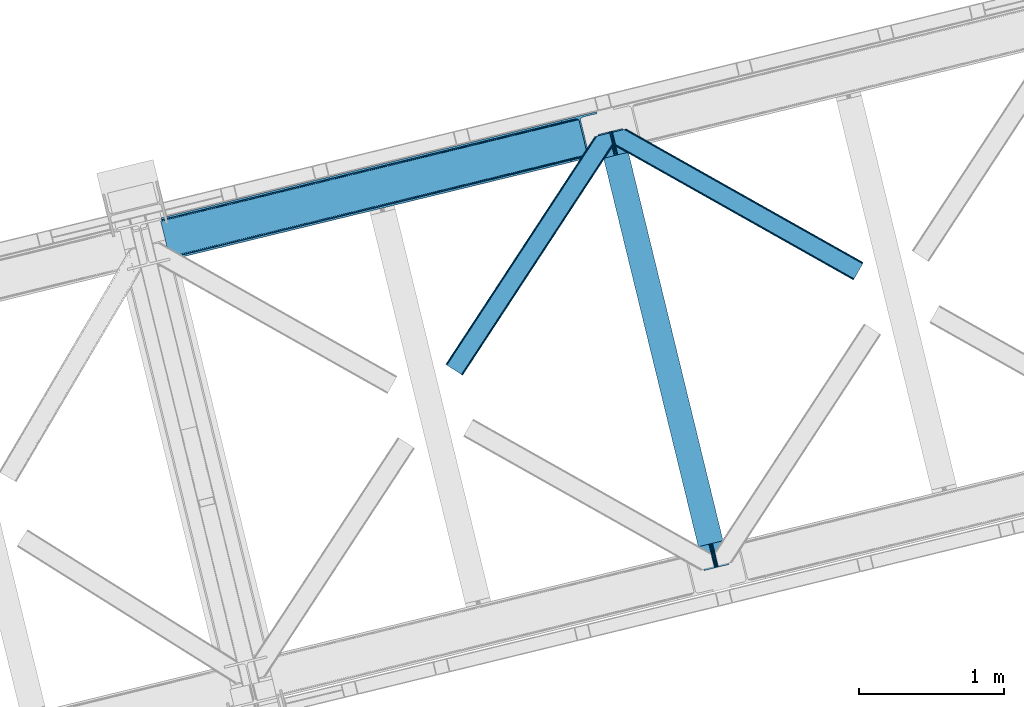
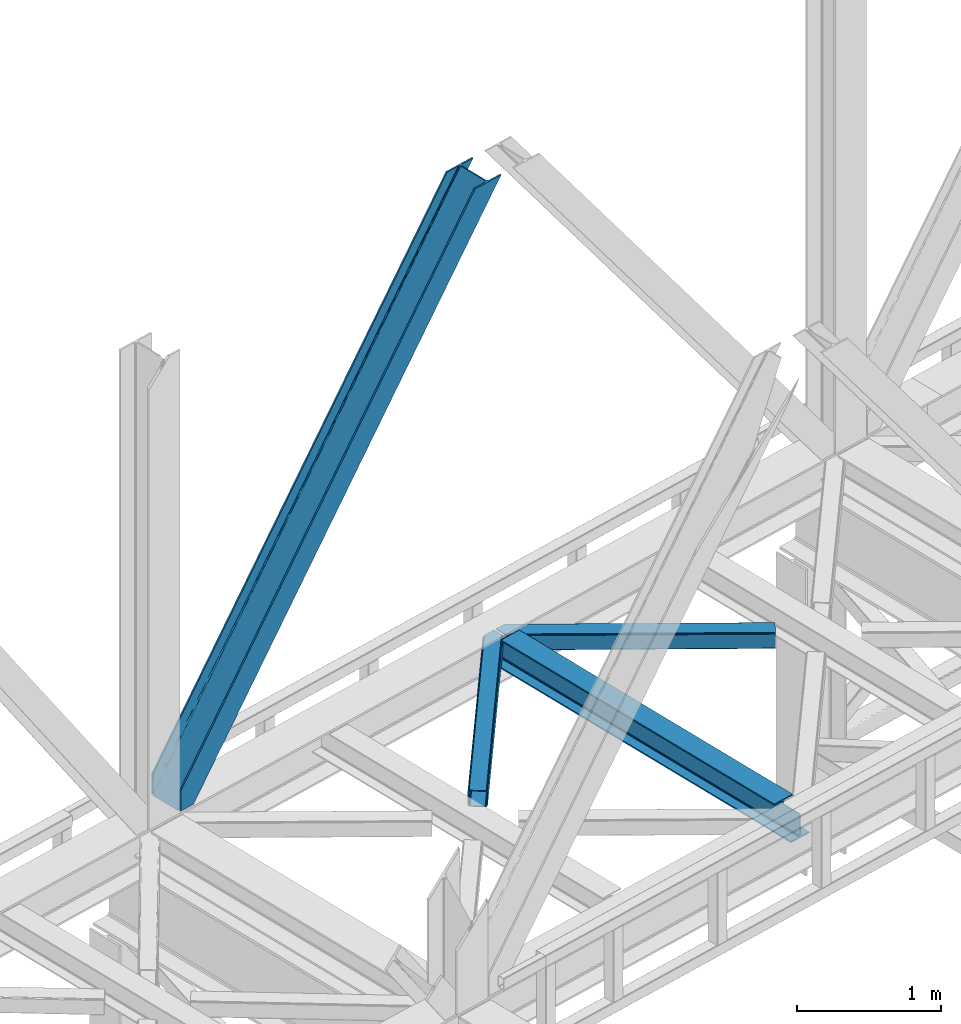
# One storey, part 40 of 93: 3 members, 1 beam.
"""IFC4 building model written with IfcOpenShell, lengths in millimetres."""

from ifc_helpers import new_model, entity, si_unit, converted_unit, derived_unit, direction, frame, origin, place, context, subcontext, project, spatial, triangles, polygons, material, type_object, element, save


model = new_model("IFC4")

# Units and contexts
model_context = context("Model", 3, precision=0.01, world=origin(), true_north=direction((6.12303176911189e-17, 1.0)))
plan_context = context("Plan", 3, precision=0.01, world=origin(), true_north=direction((6.12303176911189e-17, 1.0)))
body_context = subcontext(model_context, "Body", "Model", "MODEL_VIEW")
ifc_project = project(units=[si_unit("LENGTHUNIT", "METRE", prefix="MILLI"), si_unit("AREAUNIT", "SQUARE_METRE"), si_unit("VOLUMEUNIT", "CUBIC_METRE"), converted_unit("PLANEANGLEUNIT", "DEGREE", entity("IfcRatioMeasure", 0.0174532925199433), si_unit("PLANEANGLEUNIT", "RADIAN"), dimensions=[0, 0, 0, 0, 0, 0, 0]), si_unit("MASSUNIT", "GRAM", prefix="KILO"), derived_unit("MASSDENSITYUNIT", [(si_unit("MASSUNIT", "GRAM", prefix="KILO"), 1), (si_unit("LENGTHUNIT", "METRE"), -3)]), derived_unit("MOMENTOFINERTIAUNIT", [(si_unit("LENGTHUNIT", "METRE"), 4)]), si_unit("TIMEUNIT", "SECOND"), si_unit("FREQUENCYUNIT", "HERTZ"), si_unit("THERMODYNAMICTEMPERATUREUNIT", "DEGREE_CELSIUS"), derived_unit("THERMALTRANSMITTANCEUNIT", [(si_unit("MASSUNIT", "GRAM", prefix="KILO"), 1), (si_unit("THERMODYNAMICTEMPERATUREUNIT", "KELVIN"), -1), (si_unit("TIMEUNIT", "SECOND"), -3)]), derived_unit("VOLUMETRICFLOWRATEUNIT", [(si_unit("LENGTHUNIT", "METRE"), 3), (si_unit("TIMEUNIT", "SECOND"), -1)]), derived_unit("MASSFLOWRATEUNIT", [(si_unit("MASSUNIT", "GRAM", prefix="KILO"), 1), (si_unit("TIMEUNIT", "SECOND"), -1)]), derived_unit("ROTATIONALFREQUENCYUNIT", [(si_unit("TIMEUNIT", "SECOND"), -1)]), si_unit("ELECTRICCURRENTUNIT", "AMPERE"), si_unit("ELECTRICVOLTAGEUNIT", "VOLT"), si_unit("POWERUNIT", "WATT"), si_unit("FORCEUNIT", "NEWTON", prefix="KILO"), si_unit("ILLUMINANCEUNIT", "LUX"), si_unit("LUMINOUSFLUXUNIT", "LUMEN"), si_unit("LUMINOUSINTENSITYUNIT", "CANDELA"), derived_unit("USERDEFINED", [(si_unit("MASSUNIT", "GRAM", prefix="KILO"), -1), (si_unit("LENGTHUNIT", "METRE"), -2), (si_unit("TIMEUNIT", "SECOND"), 3), (si_unit("LUMINOUSFLUXUNIT", "LUMEN"), 1)]), derived_unit("LINEARVELOCITYUNIT", [(si_unit("LENGTHUNIT", "METRE"), 1), (si_unit("TIMEUNIT", "SECOND"), -1)]), si_unit("PRESSUREUNIT", "PASCAL"), derived_unit("USERDEFINED", [(si_unit("LENGTHUNIT", "METRE"), -2), (si_unit("MASSUNIT", "GRAM", prefix="KILO"), 1), (si_unit("TIMEUNIT", "SECOND"), -2)]), derived_unit("LINEARFORCEUNIT", [(si_unit("MASSUNIT", "GRAM", prefix="KILO"), 1), (si_unit("LENGTHUNIT", "METRE"), 1), (si_unit("TIMEUNIT", "SECOND"), -2), (si_unit("LENGTHUNIT", "METRE"), -1)]), derived_unit("PLANARFORCEUNIT", [(si_unit("MASSUNIT", "GRAM", prefix="KILO"), 1), (si_unit("LENGTHUNIT", "METRE"), 1), (si_unit("TIMEUNIT", "SECOND"), -2), (si_unit("LENGTHUNIT", "METRE"), -2)])], contexts=[model_context, plan_context])

# Site, building, storey
site_placement = place(None, origin())
site = spatial("IfcSite", under=ifc_project, at=site_placement, CompositionType="ELEMENT")
building_placement = place(site_placement, origin())
building = spatial("IfcBuilding", under=site, at=building_placement, CompositionType="ELEMENT")
storey_placement = place(building_placement, frame((0.0, 0.0, 15900.0)))
storey = spatial("IfcBuildingStorey", under=building, at=storey_placement, CompositionType="ELEMENT", Elevation=15900.0)

# Beam
ifc_material = material(Name="Metal painted (White)")
beam_type = type_object("IfcBeamType", PredefinedType="BEAM")
beam_placement = place(storey_placement, frame((-46228.4704374433, 6518.026047208, 3441.0)))
element("IfcBeam", 1, at=beam_placement, inside=storey, type_object=beam_type, material=ifc_material, ObjectType="Steel Beam", PredefinedType="BEAM", context=body_context, shape_type="Tessellation", body=[
    polygons([(900.98534618944, 41.4445662733125, 11.000000000004), (900.98534618944, 41.4445662733125, 2.16573425859679e-12), (170.021610174761, 3040.13999372697, 2.16573425859679e-12), (170.021610174761, 3040.13999372697, 11.000000000004), (834.919806235814, 25.3403919499689, 11.000000000004), (103.956070221135, 3024.03581940363, 11.000000000004), (828.971056214522, 23.8903211957407, 12.2179274798217), (98.0073201998427, 3022.5857486494, 12.2179274798217), (823.927949458422, 22.6610105689216, 15.6862915010192), (92.9642134437427, 3021.35643802258, 15.6862915010192), (820.558253255237, 21.839611468714, 20.8770650821657), (89.5945172405581, 3020.53503892237, 20.8770650821657), (819.374973305552, 21.5511744621238, 27.0000000000047), (88.4112372908723, 3020.24660191578, 27.0000000000047), (81.6103728838801, 3018.58881926485, 27.0000000000047), (81.6103728838801, 3018.58881926485, 203.000000000006), (88.4112372908723, 3020.24660191578, 203.000000000006), (0.0, 2998.69542745366, 2.16573425859679e-12), (0.0, 2998.69542745366, 10.9999999999997), (66.0655399536172, 3014.799601777, 11.000000000004), (72.0142899749184, 3016.24967253123, 12.2179274798217), (77.057396731027, 3017.47898315805, 15.6862915010192), (80.4270929341942, 3018.30038225826, 20.8770650821657), (819.374973305552, 21.5511744621238, 203.000000000006), (812.574108898559, 19.8933918111908, 203.000000000006), (812.574108898559, 19.8933918111908, 27.0000000000047), (811.390828948873, 19.6049548045995, 20.8770650821657), (808.021132745706, 18.783555704392, 15.6862915010192), (802.978025989589, 17.5542450775718, 12.2179274798217), (797.029275968296, 16.1041743233436, 11.000000000004), (730.963736014679, 3.24860138789518e-12, 10.9999999999997), (730.963736014679, 1.08286712929839e-12, 2.16573425859679e-12), (779.675212882749, 184.415062601697, 203.069791966819), (128.020401343512, 2857.75452019162, 203.000000000006), (128.243282132658, 2856.8401777572, 203.617301946336), (128.256196377177, 2856.7871977843, 217.000003693143), (779.530009633833, 185.010597404076, 217.000003676718), (779.530880241722, 185.007025963197, 204.00000679514), (772.96491171832, 182.385463974444, 203.006342981529), (772.742064056782, 183.299815969778, 203.617301946336), (772.729149812254, 183.352795942671, 217.000003693143), (121.455336555608, 2855.1293963229, 217.000003676718), (121.45446594771, 2855.13296776378, 204.00000679514), (121.310166358664, 2855.72494066435, 203.076120467494), (121.219536936511, 2856.09673754069, 203.000000000006), (780.71349435786, 185.298194377517, 223.122939328039), (784.082490766539, 186.122464201397, 228.313710402595), (789.125126170554, 187.3537084267, 231.782072735464), (795.073705041258, 188.804481281383, 232.999999602236), (861.139155906781, 204.909021065317, 232.999999283132), (861.137682570352, 204.91506504219, 243.999994005812), (691.116301666431, 163.4695582453, 243.999994827032), (691.117775002869, 163.463514268428, 233.000000104353), (757.183225868392, 179.568054052362, 232.999999785253), (763.132130996731, 181.017488520587, 231.782072861012), (768.175695503853, 182.244921343722, 228.313710479427), (771.546082413602, 183.063487001151, 223.12293937232), (120.271851831563, 2854.84179934946, 223.122939328039), (116.902855422893, 2854.01752952558, 228.313710402595), (111.860220018877, 2852.78628530027, 231.782072735464), (105.911641148165, 2851.33551244559, 232.999999602236), (39.8461902826419, 2835.23097266166, 232.999999283128), (39.8476636190794, 2835.22492868478, 243.999994005812), (209.869044522992, 2876.67043548167, 243.999994827032), (209.867571186554, 2876.67647945855, 233.000000104357), (143.802120321031, 2860.57193967461, 232.999999785253), (137.85321519271, 2859.12250520639, 231.782072861012), (132.809650685579, 2857.89507238325, 228.313710479427), (129.439263775838, 2857.07650672582, 223.12293937232)], [[[1, 2, 3, 4]], [[5, 1, 4, 6]], [[7, 5, 6, 8]], [[9, 7, 8, 10]], [[11, 9, 10, 12]], [[13, 11, 12, 14]], [[15, 16, 17, 14, 12, 10, 8, 6, 4, 3, 18, 19, 20, 21, 22, 23]], [[13, 24, 25, 26, 27, 28, 29, 30, 31, 32, 2, 1, 5, 7, 9, 11]], [[2, 32, 18, 3]], [[32, 31, 19, 18]], [[31, 30, 20, 19]], [[27, 26, 15, 23]], [[28, 27, 23, 22]], [[29, 28, 22, 21]], [[30, 29, 21, 20]], [[33, 24, 13, 14, 17, 34, 35, 36, 37, 38]], [[25, 39, 40, 41, 42, 43, 44, 16, 15, 26]], [[39, 25, 24, 33]], [[45, 34, 17, 16]], [[41, 40, 38, 37, 46, 47, 48, 49, 50, 51, 52, 53, 54, 55, 56, 57]], [[42, 58, 59, 60, 61, 62, 63, 64, 65, 66, 67, 68, 69, 36, 35, 43]], [[46, 37, 36, 69]], [[47, 46, 69, 68]], [[48, 47, 68, 67]], [[49, 48, 67, 66]], [[50, 49, 66, 65]], [[51, 50, 65, 64]], [[52, 51, 64, 63]], [[53, 52, 63, 62]], [[54, 53, 62, 61]], [[55, 54, 61, 60]], [[56, 55, 60, 59]], [[57, 56, 59, 58]], [[41, 57, 58, 42]]], closed=False),
])

# Members
member_type_1 = type_object("IfcMemberType", PredefinedType="BRACE")
member_1_placement = place(storey_placement, frame((-49235.8505126953, 8657.06402435303, 3694.99929199219)))
element("IfcMember", 2, at=member_1_placement, inside=storey, type_object=member_type_1, ObjectType="Steel Vertical Brace", PredefinedType="BRACE", context=body_context, shape_type="Tessellation", body=[
    triangles([(58.5266601562544, 27.879693603516, 0.0), (60.4474731445371, 20.0011047363296, 0.0), (59.0987182617246, 20.928955078125, 0.827856445310317), (58.9684936523481, 19.7528640747078, 1.13248901367115), (72.2095458984404, 11.65800933838, 0.0), (71.3956420898467, 13.8997329711929, 30.563250732419), (70.228271484375, 15.4356857299808, 25.1542785644524), (72.2095458984404, 11.65800933838, 171.175598144531), (71.9258422851563, 12.6195785522468, 42.2602111816377), (71.9258422851563, 12.6195785522468, 171.115136718749), (70.3910522460938, 15.5595153808608, 0.0), (68.8144042968779, 17.2873168945316, 18.6337463378877), (67.2145019531308, 18.4651519775398, 14.6921264648408), (63.1682373046933, 19.9295974731449, 7.29955444335792), (63.1682373046933, 19.9295974731449, 0.0), (67.2145019531308, 18.4651519775398, 0.0), (2821.27895507813, 682.803089904786, 3911.00081176758), (2916.00805664063, 705.89354095459, 3911.00081176758), (2933.63488769531, 721.627464294434, 3911.00081176758), (2930.26300048828, 714.795323181153, 3911.00081176758), (2933.67209472656, 728.727030944825, 3911.00081176758), (2924.07268066407, 709.270079040529, 3911.00081176758), (2824.35783691407, 670.173046875001, 3911.00081176758), (75.0512329101621, 0.0, 171.175598144531), (75.0512329101621, 0.0, 0.0), (192.881250000006, 28.7220840454102, 0.0), (3068.02668457032, 729.569421386719, 3911.00081176758), (3064.94780273438, 742.199464416504, 3911.00081176758), (189.802368164063, 41.352708435059, 0.0), (2970.22335205079, 719.109594726564, 3911.00081176758), (95.0779174804702, 18.262257385255, 0.0), (2961.50295410157, 718.394522094728, 3911.00081176758), (86.3575195312515, 17.5471847534191, 0.0), (2953.46623535157, 720.451373291016, 3911.00081176758), (78.32080078125, 19.6040359497074, 0.0), (2947.33172607422, 724.965632629395, 3911.00081176758), (72.1862915039092, 24.1188766479499, 0.0), (2944.02960205078, 731.251295471193, 3911.00081176758), (68.8841674804717, 30.4039581298839, 0.0), (2888.84692382813, 957.622943115235, 3911.00081176758), (13.7014892578154, 256.775605773926, 0.0), (2888.88878173829, 964.722509765626, 3911.00081176758), (13.7433471679688, 263.875172424318, 0.0), (2892.25601806641, 971.554650878907, 3911.00081176758), (17.1105834960981, 270.707313537598, 0.0), (2898.44633789063, 977.079313659669, 3911.00081176758), (23.3009033203125, 276.232557678224, 0.0), (2906.51561279297, 980.457014465333, 3911.00081176758), (31.3701782226563, 279.609677124025, 0.0), (3001.24006347657, 1003.54688415527, 3911.00081176758), (126.094628906256, 302.700128173828, 0.0), (2998.16118164063, 1016.17750854492, 3911.00081176758), (123.015747070313, 315.330171203614, 0.0), (2878.49406738282, 955.098678588867, 3911.00081176758), (3.3486328125, 254.25134124756, 0.0), (2869.05743408203, 965.898600769044, 3911.00081176758), (2861.01606445313, 967.955451965332, 3911.00081176758), (2754.49698486328, 956.780552673341, 3911.00081176758), (2852.30031738282, 967.24096069336, 3911.00081176758), (2757.57586669922, 944.150509643556, 3911.00081176758), (2875.19194335938, 961.384341430665, 3911.00081176758), (5.18572998046875, 286.60750579834, 171.175598144531), (5.18572998046875, 286.60750579834, 0.0), (8.02741699219041, 274.948915100098, 171.175598144531), (8.22275390625146, 273.966416931153, 171.115136718749), (8.22275390625146, 273.966416931153, 42.2602111816377), (8.02741699219041, 274.948915100098, 0.0), (3.80906982422312, 263.445547485353, 0.0), (6.72982177734957, 266.608145141603, 0.0), (8.20880126953125, 270.64917755127, 0.0), (1.42781982422457, 262.13051147461, 0.0), (3.80906982422312, 263.445547485353, 7.29955444335792), (8.33902587890771, 272.585105895996, 30.563250732419), (8.20880126953125, 270.64917755127, 24.1799194335908), (7.30653076172166, 268.181886291504, 18.3872497558586), (6.72982177734957, 266.608145141603, 14.6921264648408), (0.0, 261.670074462891, 1.13248901367115), (0.65577392578416, 260.685250854493, 0.827856445310317)], [[1, 2, 3], [4, 3, 2], [5, 6, 7], [5, 8, 9], [10, 9, 8], [9, 6, 5], [11, 12, 13], [11, 7, 12], [14, 4, 2], [2, 15, 14], [16, 13, 14], [14, 15, 16], [13, 16, 11], [7, 11, 5], [17, 18, 10], [9, 10, 18], [19, 3, 14], [14, 20, 19], [14, 13, 20], [13, 12, 20], [3, 4, 14], [19, 21, 1], [1, 3, 19], [6, 20, 7], [6, 22, 20], [12, 7, 20], [18, 22, 9], [6, 9, 22], [8, 17, 10], [23, 8, 24], [8, 23, 17], [25, 24, 5], [8, 5, 24], [23, 26, 27], [26, 23, 24], [25, 26, 24], [28, 27, 29], [26, 29, 27], [30, 28, 29], [29, 31, 30], [32, 30, 31], [31, 33, 32], [34, 32, 33], [33, 35, 34], [36, 34, 35], [35, 37, 36], [38, 36, 37], [37, 39, 38], [40, 38, 39], [39, 41, 40], [42, 40, 43], [41, 43, 40], [44, 42, 45], [43, 45, 42], [46, 44, 47], [45, 47, 44], [48, 46, 49], [47, 49, 46], [50, 48, 51], [49, 51, 48], [52, 50, 53], [51, 53, 50], [21, 54, 55], [55, 1, 21], [54, 21, 40], [20, 22, 32], [18, 23, 27], [17, 23, 18], [22, 18, 30], [21, 19, 36], [19, 20, 34], [56, 46, 57], [58, 59, 52], [59, 57, 48], [58, 60, 59], [56, 61, 44], [61, 54, 42], [40, 21, 38], [30, 32, 22], [36, 19, 34], [32, 34, 20], [36, 38, 21], [27, 30, 18], [27, 28, 30], [48, 57, 46], [44, 61, 42], [40, 42, 54], [44, 46, 56], [48, 52, 59], [52, 48, 50], [58, 53, 62], [58, 52, 53], [53, 63, 62], [64, 58, 62], [60, 64, 65], [64, 60, 58], [59, 60, 65], [65, 66, 59], [67, 64, 62], [62, 63, 67], [11, 35, 5], [68, 41, 55], [69, 70, 43], [69, 43, 68], [55, 71, 68], [67, 63, 47], [67, 45, 70], [55, 39, 1], [37, 16, 15], [2, 1, 15], [15, 1, 39], [11, 16, 37], [25, 5, 33], [39, 55, 41], [49, 47, 63], [43, 70, 45], [47, 45, 67], [43, 41, 68], [53, 49, 63], [53, 51, 49], [31, 25, 33], [35, 11, 37], [39, 37, 15], [35, 33, 5], [31, 26, 25], [26, 31, 29], [72, 68, 71], [67, 73, 66], [67, 70, 74], [74, 73, 67], [64, 67, 66], [66, 65, 64], [75, 70, 76], [75, 74, 70], [69, 76, 70], [76, 69, 72], [68, 72, 69], [71, 77, 72], [78, 61, 72], [61, 56, 75], [75, 76, 61], [76, 72, 61], [56, 57, 73], [73, 74, 56], [57, 59, 66], [66, 73, 57], [74, 75, 56], [72, 77, 78], [54, 61, 55], [78, 55, 61], [71, 55, 78], [78, 77, 71]]),
])
member_type_2 = type_object("IfcMemberType", PredefinedType="BRACE")
member_2_placement = place(storey_placement, frame((-47275.2632080078, 7859.97314300537, 3511.0000579834)))
element("IfcMember", 3, at=member_2_placement, inside=storey, type_object=member_type_2, ObjectType="Steel Horizontal Brace", PredefinedType="BRACE", context=body_context, shape_type="Tessellation", body=[
    triangles([(994.771838378903, 1564.02662658691, 0.0), (1028.82092285156, 1424.34736175537, 0.0), (14.6409667968692, 67.104043579101, 0.0), (102.482116699219, 9.58604278564417, 0.0), (1.11156005859084, 75.9604797363281, 10.8028289794929), (0.0, 76.6900863647461, 17.5000946044929), (1025.02580566406, 1642.17883300781, 17.5000946044929), (4.28811035156104, 73.8821182250977, 5.12526855468968), (990.474426269531, 1585.87703704834, 9.50058288574292), (990.041894531249, 1584.44747314453, 8.74132690429906), (989.907019042963, 1583.99226837158, 8.50064392089917), (990.758129882808, 1580.48841247559, 5.12526855468968), (1027.30473632812, 1642.73519439697, 10.8702667236357), (1027.77912597656, 1642.8503036499, 9.50058288574292), (992.599877929686, 1572.93538513184, 1.33247680664135), (9.03665771483793, 70.7724243164057, 1.33247680664135), (1025.02580566406, 1642.17883300781, 122.500662231447), (0.0, 76.6900863647461, 122.500662231447), (1026.9187133789, 1642.64101409912, 129.197927856447), (1.11156005859084, 75.9604797363281, 129.197927856447), (1032.31373291015, 1643.95605010986, 134.874325561526), (4.28811035156104, 73.8821182250977, 134.874325561526), (1040.39230957031, 1645.92395324707, 138.667117309571), (9.03665771483793, 70.7724243164057, 138.667117309571), (1049.91730957031, 1648.24590454102, 139.999594116212), (14.6409667968692, 67.104043579101, 139.999594116212), (994.869506835938, 1567.85139312744, 9.50058288574292), (994.757885742183, 1567.00667724609, 9.29478149414354), (994.646264648436, 1566.15091552734, 9.08781738281323), (994.539294433591, 1565.306199646, 8.8831787109375), (994.743933105463, 1564.14464263916, 8.50064392089917), (1047.05236816406, 1647.54827270508, 9.50058288574292), (14.892114257811, 66.9377746582031, 8.3320495605476), (20.4964233398423, 63.2693939208984, 6.99957275390625), (997.041467285155, 1554.71498565674, 6.99957275390625), (10.1435668945269, 70.0474685668942, 12.1260040283232), (1042.27126464844, 1646.3826461792, 12.1260040283232), (1036.87624511719, 1645.06761016846, 17.8035644531265), (1034.98333740234, 1644.60601043701, 24.4996673583992), (6.96701660155668, 72.1258300781246, 17.8035644531265), (5.85545654296584, 72.8554367065426, 24.4996673583992), (1026.55129394531, 1433.65958404541, 6.99957275390625), (96.6266601562456, 13.4206924438477, 6.99957275390625), (1028.71395263672, 1424.77640533447, 8.41343994140698), (1032.83463134765, 1407.88615722656, 5.12526855468968), (1033.6857421875, 1404.38230133057, 8.50064392089917), (1030.99288330078, 1415.43918457031, 1.33247680664135), (1034.98333740234, 1644.60601043701, 115.501089477541), (5.85545654296584, 72.8554367065426, 115.501089477541), (1050.34519042968, 1648.35113067627, 131.667544555665), (1059.87019042968, 1650.67308197021, 133.000021362306), (20.4964233398423, 63.2693939208984, 133.000021362306), (14.892114257811, 66.9377746582031, 131.667544555665), (1042.27126464844, 1646.3826461792, 127.87475280762), (10.1435668945269, 70.0474685668942, 127.87475280762), (1036.87624511719, 1645.06761016846, 122.196029663086), (6.96701660155668, 72.1258300781246, 122.196029663086), (1128.10788574218, 1667.30578765869, 139.999594116212), (1128.10788574218, 1667.30578765869, 133.000021362306), (1144.32550048828, 1600.75810546875, 139.999594116212), (102.482116699219, 9.58604278564417, 139.999594116212), (1142.05587158203, 1610.06974639893, 133.000021362306), (96.6266601562456, 13.4206924438477, 133.000021362306), (1146.4974609375, 1591.84934692383, 138.667117309571), (108.08642578125, 5.91766204833948, 138.667117309571), (1148.33920898437, 1584.29631958008, 134.874325561526), (112.834973144527, 2.80738677978479, 134.874325561526), (1149.57169189453, 1579.2501159668, 129.197927856447), (116.011523437497, 0.729606628417969, 129.197927856447), (1150.00422363281, 1577.47813110352, 122.500662231447), (117.123083496088, 0.0, 122.500662231447), (1150.00422363281, 1577.47813110352, 17.5000946044929), (117.123083496088, 0.0, 17.5000946044929), (106.979516601561, 6.64203643798828, 127.87475280762), (110.151416015622, 4.56425628662055, 122.196029663086), (111.267626953122, 3.83464965820258, 115.501089477541), (102.230969238277, 9.75231170654297, 131.667544555665), (116.011523437497, 0.729606628417969, 10.8028289794929), (106.979516601561, 6.64203643798828, 12.1260040283232), (112.834973144527, 2.80738677978479, 5.12526855468968), (111.267626953122, 3.83464965820258, 24.4996673583992), (110.151416015622, 4.56425628662055, 17.8035644531265), (108.08642578125, 5.91766204833948, 1.33247680664135), (102.230969238277, 9.75231170654297, 8.3320495605476), (1147.30206298828, 1588.56233825684, 122.196029663086), (1147.73459472656, 1586.78977203369, 115.501089477541), (1146.06958007813, 1593.60854187012, 127.87475280762), (1144.22783203125, 1601.160987854, 131.667544555665), (1147.73459472656, 1586.78977203369, 24.4996673583992), (1147.21369628906, 1588.9239440918, 17.869839477542), (1149.994921875, 1577.51591949463, 16.5001556396492), (1147.10672607421, 1589.36519622803, 16.5001556396492), (1145.27427978515, 1573.10804901123, 10.8714294433594), (1034.61591796875, 1404.78809051514, 9.50058288574292), (1144.12551269531, 1572.03427734375, 9.50058288574292), (1142.79071044922, 1588.5978012085, 12.1260040283232), (1030.22548828125, 1422.8143157959, 9.50058288574292), (1029.19764404296, 1423.6724029541, 8.80643920898729), (1139.7304321289, 1590.05992126465, 9.50058288574292)], [[1, 2, 3], [4, 3, 2], [5, 6, 7], [8, 9, 10], [11, 12, 8], [5, 13, 9], [9, 8, 5], [13, 14, 9], [15, 1, 16], [3, 16, 1], [12, 15, 8], [16, 8, 15], [7, 13, 5], [17, 7, 18], [6, 18, 7], [19, 17, 20], [18, 20, 17], [21, 19, 22], [20, 22, 19], [23, 21, 24], [22, 24, 21], [25, 23, 26], [24, 26, 23], [27, 28, 9], [28, 29, 10], [29, 30, 10], [30, 31, 11], [14, 32, 27], [27, 9, 14], [33, 34, 35], [36, 33, 31], [31, 30, 36], [28, 36, 29], [28, 27, 36], [36, 30, 29], [32, 37, 27], [36, 27, 37], [35, 31, 33], [38, 39, 40], [41, 40, 39], [37, 38, 36], [40, 36, 38], [42, 35, 34], [34, 43, 42], [1, 35, 42], [31, 12, 11], [1, 31, 35], [31, 15, 12], [31, 1, 15], [2, 1, 42], [44, 2, 42], [45, 44, 46], [44, 47, 2], [44, 45, 47], [39, 48, 41], [49, 41, 48], [50, 51, 52], [52, 53, 50], [54, 50, 53], [53, 55, 54], [56, 54, 55], [55, 57, 56], [48, 56, 57], [57, 49, 48], [56, 17, 19], [50, 23, 25], [58, 51, 25], [51, 58, 59], [51, 50, 25], [54, 23, 50], [54, 56, 21], [21, 23, 54], [19, 21, 56], [39, 7, 17], [37, 14, 38], [56, 48, 17], [37, 32, 14], [39, 38, 7], [48, 39, 17], [13, 7, 38], [38, 14, 13], [60, 25, 61], [25, 60, 58], [26, 61, 25], [51, 62, 63], [51, 59, 62], [63, 52, 51], [64, 60, 61], [61, 65, 64], [66, 64, 65], [65, 67, 66], [68, 66, 67], [67, 69, 68], [70, 68, 69], [69, 71, 70], [72, 70, 71], [71, 73, 72], [69, 74, 75], [76, 73, 71], [69, 75, 71], [69, 67, 74], [75, 76, 71], [74, 67, 65], [63, 61, 26], [61, 77, 65], [77, 61, 63], [77, 74, 65], [78, 79, 80], [81, 73, 76], [73, 82, 78], [82, 73, 81], [78, 82, 79], [4, 43, 3], [83, 80, 79], [79, 84, 83], [84, 43, 4], [4, 83, 84], [55, 24, 22], [26, 52, 63], [26, 53, 52], [53, 26, 24], [55, 53, 24], [49, 18, 6], [20, 57, 55], [22, 20, 55], [57, 20, 18], [49, 57, 18], [16, 36, 8], [3, 43, 34], [34, 33, 3], [33, 36, 16], [16, 3, 33], [5, 8, 36], [6, 41, 49], [40, 6, 5], [6, 40, 41], [40, 5, 36], [85, 86, 75], [76, 75, 86], [87, 85, 74], [75, 74, 85], [88, 87, 77], [74, 77, 87], [62, 88, 63], [77, 63, 88], [86, 89, 81], [81, 76, 86], [90, 91, 92], [70, 72, 89], [72, 90, 89], [89, 86, 70], [72, 91, 90], [85, 70, 86], [68, 70, 85], [66, 85, 87], [85, 66, 68], [87, 64, 66], [88, 64, 87], [88, 62, 60], [88, 60, 64], [62, 58, 60], [62, 59, 58], [73, 78, 93], [93, 72, 73], [94, 93, 78], [94, 95, 93], [80, 45, 46], [46, 78, 80], [46, 94, 78], [47, 45, 83], [80, 83, 45], [2, 47, 4], [83, 4, 47], [93, 91, 72], [82, 81, 89], [82, 92, 96], [82, 90, 92], [84, 97, 98], [79, 96, 97], [97, 84, 79], [96, 99, 97], [43, 84, 44], [44, 42, 43], [96, 79, 82], [89, 90, 82], [96, 91, 93], [96, 92, 91], [96, 95, 99], [93, 95, 96], [99, 95, 97], [94, 97, 95]]),
])
member_type_3 = type_object("IfcMemberType", PredefinedType="BRACE")
member_3_placement = place(storey_placement, frame((-46126.7565673828, 8515.07327270508, 3511.0000579834)))
element("IfcMember", 4, at=member_3_placement, inside=storey, type_object=member_type_3, ObjectType="Steel Horizontal Brace", PredefinedType="BRACE", context=body_context, shape_type="Tessellation", body=[
    triangles([(1656.08961181641, 0.0, 122.500662231447), (1656.74538574219, 1.16097564697338, 129.197927856447), (23.8915649414048, 919.172964477539, 122.500662231447), (23.4590332031221, 920.944949340821, 129.197927856447), (1658.60573730469, 4.46600646972729, 134.874325561526), (22.231201171875, 925.991734313966, 134.874325561526), (1661.39161376953, 9.41337890625073, 138.667117309571), (20.3894531249971, 933.544180297851, 138.667117309571), (1664.67978515625, 15.2484878540035, 139.999594116212), (18.2174926757798, 942.452938842775, 139.999594116212), (1656.08961181641, 0.0, 17.5000946044929), (23.8915649414048, 919.172964477539, 17.5000946044929), (1716.20222167969, 106.738252258301, 139.999594116212), (69.4469238281235, 1034.10722808838, 139.999594116212), (0.0, 1017.17919158936, 139.999594116212), (1719.4857421875, 112.573361206056, 138.667117309571), (78.971923828125, 1036.42917938232, 138.667117309571), (1722.27161865235, 117.520152282716, 134.874325561526), (87.0458496093779, 1038.39708251953, 134.874325561526), (1724.13662109375, 120.825764465333, 129.197927856447), (92.4455200195298, 1039.71269989014, 129.197927856447), (1724.78774414062, 121.986740112305, 122.500662231447), (94.3384277343721, 1040.17429962158, 122.500662231447), (1724.78774414062, 121.986740112305, 17.5000946044929), (94.3384277343721, 1040.17429962158, 17.5000946044929), (1656.74538574219, 1.16097564697338, 10.8028289794929), (1658.60573730469, 4.46600646972729, 5.12526855468968), (196.057800292969, 824.821165466308, 8.8831787109375), (196.076403808591, 825.066499328614, 8.50064392089917), (23.3706665039063, 921.307136535645, 10.8691040039084), (195.062512207034, 824.998480224609, 9.50058288574292), (195.732238769531, 824.878720092775, 9.08316650390771), (23.263696289061, 921.747807312013, 9.50058288574292), (195.225292968753, 828.57035522461, 5.12526855468968), (1664.67978515625, 15.2484878540035, 0.0), (1661.39161376953, 9.41337890625073, 1.33247680664135), (193.383544921875, 836.123382568359, 1.33247680664135), (191.211584472658, 845.031559753419, 0.0), (1716.20222167969, 106.738252258301, 0.0), (157.162499999999, 984.710824584961, 0.0), (191.351110839845, 843.223530578614, 9.20757751465135), (191.295300292972, 844.068827819825, 8.85411071777344), (191.104614257813, 845.46060333252, 8.41343994140698), (18.8686157226548, 939.774032592773, 9.50058288574292), (1724.13662109375, 120.825764465333, 10.8028289794929), (92.0548461914077, 1039.61851959229, 10.8702667236357), (150.921020507813, 1006.08742675781, 9.50058288574292), (1722.27161865235, 117.520152282716, 5.12526855468968), (153.148791503903, 1001.17261047363, 5.12526855468968), (152.297680664065, 1004.67646636963, 8.50064392089917), (151.609350585939, 1005.38223724365, 9.00061340332104), (91.5851074218735, 1039.50341033936, 9.50058288574292), (1719.4857421875, 112.573361206056, 1.33247680664135), (154.990539550781, 993.620164489746, 1.33247680664135), (156.250927734378, 986.7019821167, 9.11688537597729), (155.813745117186, 987.634483337402, 9.42384338378906), (156.692761230472, 985.761341857911, 8.80760192871094), (157.134594726565, 984.828840637207, 8.50064392089917), (155.316101074219, 988.061782836914, 9.50058288574292), (72.3118652343765, 1034.80544128418, 9.50058288574292), (159.43212890625, 975.399183654785, 6.99957275390625), (188.941955566406, 854.343782043457, 6.99957275390625), (1668.11213378907, 21.3475341796875, 6.99957275390625), (1712.76522216797, 100.639205932617, 6.99957275390625), (19.9615722656235, 935.303375244141, 12.1260040283232), (1662.04273681641, 10.5656341552731, 12.1260040283232), (1664.82861328125, 15.5124252319347, 8.3320495605476), (1659.52661132813, 6.09904632568396, 24.4996673583992), (1660.177734375, 7.26002197265734, 17.8035644531265), (21.6219360351533, 928.484605407715, 24.4996673583992), (21.1894042968779, 930.257171630859, 17.8035644531265), (1716.05339355468, 106.474314880372, 8.3320495605476), (1718.83927001953, 111.421105957032, 12.1260040283232), (77.0929687500029, 1035.9704864502, 12.1260040283232), (1720.69962158203, 114.726718139649, 17.8035644531265), (82.4879882812529, 1037.28552246094, 17.8035644531265), (1721.35074462891, 115.887112426759, 24.4996673583992), (84.3808959960952, 1037.74770355225, 24.4996673583992), (1659.52661132813, 6.09904632568396, 115.501089477541), (21.6219360351533, 928.484605407715, 115.501089477541), (21.1894042968779, 930.257171630859, 122.196029663086), (19.9615722656235, 935.303375244141, 127.87475280762), (15.9478637695283, 951.764579772949, 133.000021362306), (18.1198242187529, 942.855821228028, 131.667544555665), (0.0, 1017.17919158936, 133.000021362306), (1668.11213378907, 21.3475341796875, 133.000021362306), (1664.82861328125, 15.5124252319347, 131.667544555665), (1662.04273681641, 10.5656341552731, 127.87475280762), (1660.177734375, 7.26002197265734, 122.196029663086), (1718.83927001953, 111.421105957032, 127.87475280762), (1720.69962158203, 114.726718139649, 122.196029663086), (1721.35074462891, 115.887112426759, 115.501089477541), (1712.76522216797, 100.639205932617, 133.000021362306), (1716.05339355468, 106.474314880372, 131.667544555665), (77.0929687500029, 1035.9704864502, 127.87475280762), (69.01904296875, 1034.00258331299, 131.667544555665), (82.4879882812529, 1037.28552246094, 122.196029663086), (59.4940429687485, 1031.68063201904, 133.000021362306), (84.3808959960952, 1037.74770355225, 115.501089477541)], [[1, 2, 3], [4, 3, 2], [2, 5, 4], [6, 4, 5], [5, 7, 6], [8, 6, 7], [7, 9, 8], [10, 8, 9], [11, 1, 12], [3, 12, 1], [13, 10, 9], [10, 13, 14], [15, 10, 14], [13, 16, 17], [17, 14, 13], [16, 18, 19], [19, 17, 16], [18, 20, 21], [21, 19, 18], [20, 22, 23], [23, 21, 20], [22, 24, 25], [25, 23, 22], [26, 11, 12], [27, 28, 29], [26, 30, 31], [31, 27, 26], [31, 32, 27], [30, 33, 31], [29, 34, 27], [35, 36, 37], [37, 38, 35], [36, 27, 34], [34, 37, 36], [12, 30, 26], [39, 35, 38], [38, 40, 39], [41, 42, 29], [42, 43, 29], [41, 31, 33], [33, 44, 41], [45, 46, 25], [46, 45, 47], [45, 48, 49], [49, 50, 45], [45, 50, 51], [51, 47, 45], [47, 52, 46], [48, 53, 54], [54, 49, 48], [53, 39, 40], [40, 54, 53], [25, 24, 45], [51, 55, 56], [50, 57, 55], [50, 58, 57], [47, 59, 52], [60, 52, 59], [61, 40, 62], [54, 58, 49], [58, 54, 40], [49, 58, 50], [40, 61, 58], [62, 40, 38], [37, 43, 38], [43, 37, 34], [38, 43, 62], [34, 29, 43], [63, 64, 62], [61, 62, 64], [63, 62, 43], [41, 65, 66], [41, 44, 65], [43, 66, 67], [66, 43, 42], [42, 41, 66], [43, 67, 63], [68, 69, 70], [71, 70, 69], [69, 66, 71], [65, 71, 66], [72, 58, 61], [57, 72, 55], [57, 58, 72], [56, 55, 72], [73, 74, 59], [59, 72, 73], [74, 60, 59], [73, 75, 76], [76, 74, 73], [75, 77, 78], [78, 76, 75], [61, 64, 72], [79, 68, 80], [70, 80, 68], [81, 6, 82], [80, 70, 3], [4, 81, 3], [81, 4, 6], [81, 80, 3], [70, 12, 3], [71, 65, 33], [33, 30, 71], [30, 12, 71], [70, 71, 12], [83, 10, 15], [10, 84, 8], [84, 10, 83], [15, 85, 83], [84, 82, 8], [44, 33, 65], [8, 82, 6], [86, 87, 84], [84, 83, 86], [87, 88, 82], [82, 84, 87], [88, 89, 81], [81, 82, 88], [89, 79, 80], [80, 81, 89], [20, 90, 91], [92, 24, 22], [20, 91, 22], [20, 18, 90], [91, 92, 22], [90, 18, 16], [93, 13, 9], [13, 94, 16], [94, 13, 93], [94, 90, 16], [45, 73, 48], [77, 24, 92], [24, 75, 45], [75, 24, 77], [45, 75, 73], [39, 64, 35], [53, 48, 73], [73, 72, 53], [72, 64, 39], [39, 53, 72], [88, 7, 5], [9, 86, 93], [9, 87, 86], [87, 9, 7], [88, 87, 7], [79, 1, 11], [2, 89, 88], [5, 2, 88], [89, 2, 1], [79, 89, 1], [36, 66, 27], [35, 64, 63], [63, 67, 35], [67, 66, 36], [36, 35, 67], [26, 27, 66], [11, 68, 79], [69, 11, 26], [11, 69, 68], [69, 26, 66], [95, 96, 17], [19, 95, 17], [19, 21, 97], [95, 19, 97], [97, 21, 23], [96, 14, 17], [15, 98, 85], [15, 14, 98], [96, 98, 14], [97, 23, 99], [78, 25, 76], [23, 78, 99], [25, 46, 76], [23, 25, 78], [52, 76, 46], [74, 76, 52], [60, 74, 52], [93, 83, 98], [93, 86, 83], [83, 85, 98], [77, 92, 78], [99, 78, 92], [92, 91, 99], [97, 99, 91], [91, 90, 97], [95, 97, 90], [90, 94, 95], [96, 95, 94], [94, 93, 96], [98, 96, 93]]),
])

save(model, "model.ifc")
